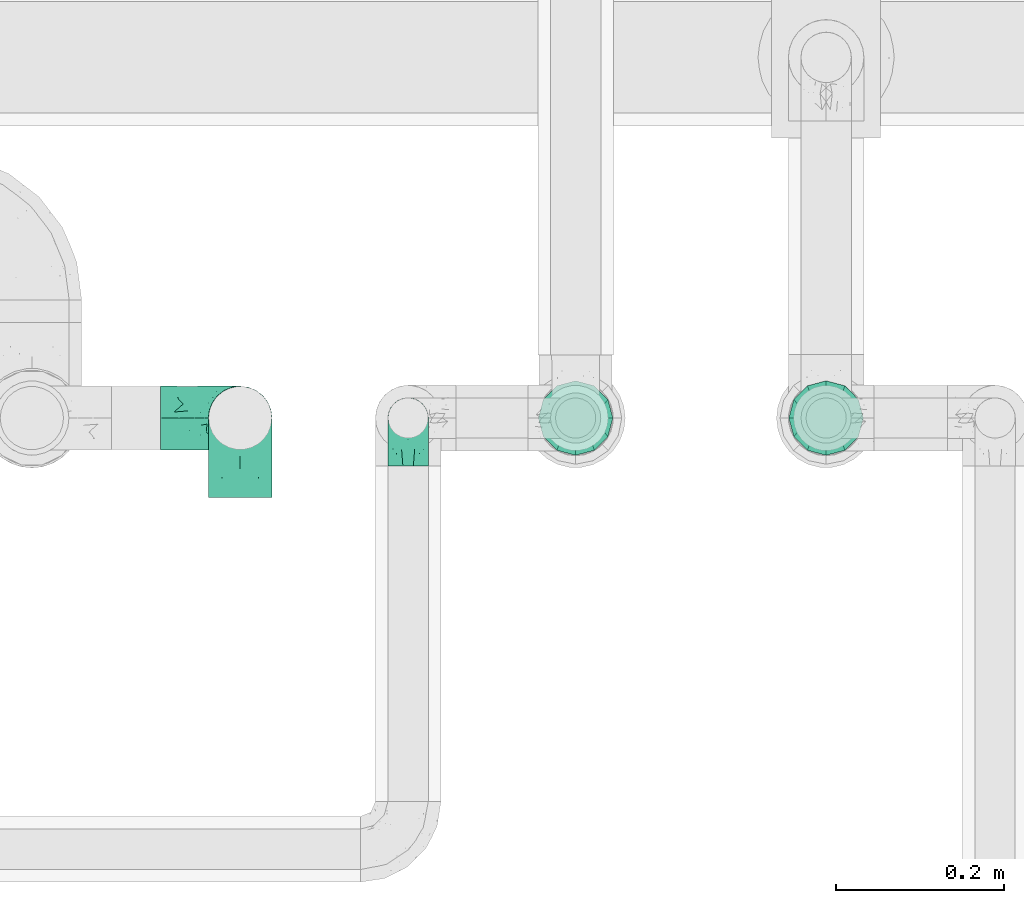
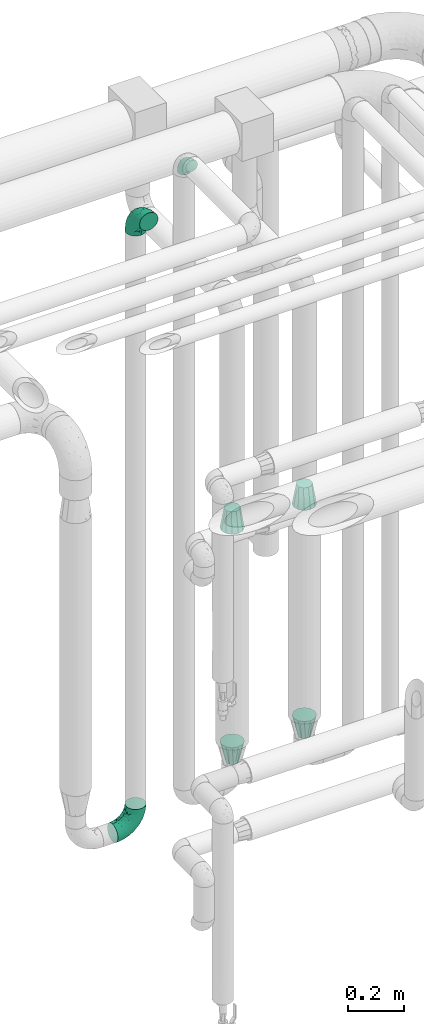
# One storey, part 717 of 827: 7 flow fittings.
"""IFC2X3 building model written with IfcOpenShell, lengths in millimetres."""

from ifc_helpers import new_model, entity, si_unit, converted_unit, derived_unit, direction, frame, origin, place, context, subcontext, project, spatial, faceted_brep, source, transform, mapped, material, type_object, type_shapes, element, save


model = new_model("IFC2X3")

# Units and contexts
model_context = context("Model", 3, precision=0.01, world=origin(), true_north=direction((6.12303176911189e-17, 1.0)))
body_context = subcontext(model_context, "Body", "Model", "MODEL_VIEW")
ifc_project = project(units=[si_unit("LENGTHUNIT", "METRE", prefix="MILLI"), si_unit("AREAUNIT", "SQUARE_METRE"), si_unit("VOLUMEUNIT", "CUBIC_METRE"), converted_unit("PLANEANGLEUNIT", "DEGREE", entity("IfcRatioMeasure", 0.0174532925199433), si_unit("PLANEANGLEUNIT", "RADIAN"), dimensions=[0, 0, 0, 0, 0, 0, 0]), si_unit("MASSUNIT", "GRAM", prefix="KILO"), derived_unit("MASSDENSITYUNIT", [(si_unit("MASSUNIT", "GRAM", prefix="KILO"), 1), (si_unit("LENGTHUNIT", "METRE"), -3)]), derived_unit("MOMENTOFINERTIAUNIT", [(si_unit("LENGTHUNIT", "METRE"), 4)]), si_unit("TIMEUNIT", "SECOND"), si_unit("FREQUENCYUNIT", "HERTZ"), si_unit("THERMODYNAMICTEMPERATUREUNIT", "DEGREE_CELSIUS"), derived_unit("THERMALTRANSMITTANCEUNIT", [(si_unit("MASSUNIT", "GRAM", prefix="KILO"), 1), (si_unit("THERMODYNAMICTEMPERATUREUNIT", "KELVIN"), -1), (si_unit("TIMEUNIT", "SECOND"), -3)]), derived_unit("VOLUMETRICFLOWRATEUNIT", [(si_unit("LENGTHUNIT", "METRE"), 3), (si_unit("TIMEUNIT", "SECOND"), -1)]), derived_unit("MASSFLOWRATEUNIT", [(si_unit("MASSUNIT", "GRAM", prefix="KILO"), 1), (si_unit("TIMEUNIT", "SECOND"), -1)]), derived_unit("ROTATIONALFREQUENCYUNIT", [(si_unit("TIMEUNIT", "SECOND"), -1)]), si_unit("ELECTRICCURRENTUNIT", "AMPERE"), si_unit("ELECTRICVOLTAGEUNIT", "VOLT"), si_unit("POWERUNIT", "WATT"), si_unit("FORCEUNIT", "NEWTON", prefix="KILO"), si_unit("ILLUMINANCEUNIT", "LUX"), si_unit("LUMINOUSFLUXUNIT", "LUMEN"), si_unit("LUMINOUSINTENSITYUNIT", "CANDELA"), derived_unit("USERDEFINED", [(si_unit("MASSUNIT", "GRAM", prefix="KILO"), -1), (si_unit("LENGTHUNIT", "METRE"), -2), (si_unit("TIMEUNIT", "SECOND"), 3), (si_unit("LUMINOUSFLUXUNIT", "LUMEN"), 1)]), derived_unit("LINEARVELOCITYUNIT", [(si_unit("LENGTHUNIT", "METRE"), 1), (si_unit("TIMEUNIT", "SECOND"), -1)]), si_unit("PRESSUREUNIT", "PASCAL"), derived_unit("USERDEFINED", [(si_unit("LENGTHUNIT", "METRE"), -2), (si_unit("MASSUNIT", "GRAM", prefix="KILO"), 1), (si_unit("TIMEUNIT", "SECOND"), -2)]), derived_unit("LINEARFORCEUNIT", [(si_unit("MASSUNIT", "GRAM", prefix="KILO"), 1), (si_unit("LENGTHUNIT", "METRE"), 1), (si_unit("TIMEUNIT", "SECOND"), -2), (si_unit("LENGTHUNIT", "METRE"), -1)]), derived_unit("PLANARFORCEUNIT", [(si_unit("MASSUNIT", "GRAM", prefix="KILO"), 1), (si_unit("LENGTHUNIT", "METRE"), 1), (si_unit("TIMEUNIT", "SECOND"), -2), (si_unit("LENGTHUNIT", "METRE"), -2)])], contexts=[model_context])

# Site, building, storey
site_placement = place(None, origin())
site = spatial("IfcSite", under=ifc_project, at=site_placement, CompositionType="ELEMENT")
building_placement = place(site_placement, origin())
building = spatial("IfcBuilding", under=site, at=building_placement, CompositionType="ELEMENT")
storey_placement = place(building_placement, frame((0.0, 0.0, 28200.0)))
storey = spatial("IfcBuildingStorey", under=building, at=storey_placement, Name="08", CompositionType="ELEMENT", Elevation=28200.0)

# Flow fittings
ifc_material = material()
pipe_fitting_type_1 = type_object("IfcPipeFittingType", Name="ADSK_1", PredefinedType="NOTDEFINED", material=ifc_material)
shared_shape_1 = source(origin(), body_context, "Body", "Brep", [
    faceted_brep([(-57.0, 12.07, -20.91), (-57.0, 6.25, -23.33), (-57.0, 0.0, -24.15), (-57.0, -6.25, -23.33), (-57.0, -12.08, -20.91), (-57.0, -17.08, -17.08), (-57.0, -20.91, -12.08), (-57.0, -23.33, -6.25), (-57.0, -24.15, 0.0), (-57.0, -23.33, 6.25), (-57.0, -20.91, 12.07), (-57.0, -17.08, 17.08), (-57.0, -12.08, 20.91), (-57.0, -6.25, 23.33), (-57.0, 0.0, 24.15), (-57.0, 6.25, 23.33), (-57.0, 12.07, 20.91), (-57.0, 17.08, 17.08), (-57.0, 20.91, 12.07), (-57.0, 23.33, 6.25), (-57.0, 24.15, 0.0), (-57.0, 23.33, -6.25), (-57.0, 20.91, -12.08), (-57.0, 17.08, -17.08), (0.0, 57.0, -24.15), (-6.25, 57.0, -23.33), (-12.07, 57.0, -20.91), (-17.08, 57.0, -17.08), (-20.91, 57.0, -12.08), (-23.33, 57.0, -6.25), (-24.15, 57.0, 0.0), (-23.33, 57.0, 6.25), (-20.91, 57.0, 12.07), (-17.08, 57.0, 17.08), (-12.07, 57.0, 20.91), (-6.25, 57.0, 23.33), (0.0, 57.0, 24.15), (6.25, 57.0, 23.33), (12.08, 57.0, 20.91), (17.08, 57.0, 17.08), (20.91, 57.0, 12.07), (23.33, 57.0, 6.25), (24.15, 57.0, 0.0), (23.33, 57.0, -6.25), (20.91, 57.0, -12.08), (17.08, 57.0, -17.08), (12.08, 57.0, -20.91), (6.25, 57.0, -23.33), (14.9, 21.14, 6.17), (13.61, 24.64, 12.48), (6.23, 8.95, 8.98), (-41.47, -21.06, 0.0), (-41.92, -18.38, 13.72), (-24.64, -13.61, 12.48), (-37.37, -13.24, 18.15), (-6.8, -4.93, 8.18), (-21.76, -15.19, 6.22), (-12.78, -9.18, 0.0), (-37.73, -20.51, 7.75), (-7.38, 7.38, 20.24), (-23.37, -4.26, 20.42), (-11.9, -3.19, 15.86), (-42.14, -8.7, 21.82), (13.24, 37.37, 18.15), (9.33, 23.53, 16.85), (4.26, 23.37, 20.42), (2.77, 10.92, 15.55), (-29.46, 0.91, 23.52), (-44.13, 20.56, 15.69), (-39.25, 26.33, 10.88), (-49.02, 22.92, 9.96), (-34.58, 23.87, 17.15), (-15.8, 6.8, 22.81), (-8.67, 20.47, 23.88), (-18.12, 12.9, 24.08), (-48.29, 14.92, 19.65), (-44.06, -2.85, 23.78), (-9.23, 48.95, 22.58), (-3.78, 42.74, 24.07), (-40.34, 4.26, 24.09), (-44.02, 26.14, 5.46), (-44.04, 9.88, 22.74), (-4.95, 16.87, 22.52), (-2.75, 1.43, 12.5), (-25.48, 40.98, 10.71), (20.51, 37.73, 7.75), (18.38, 41.92, 13.72), (8.7, 42.14, 21.82), (-25.95, -17.97, 0.0), (2.85, 44.06, 23.78), (21.06, 41.47, 0.0), (17.97, 25.95, 0.0), (-24.04, -9.27, 17.13), (-33.26, 33.26, 5.86), (-28.55, 40.57, 0.0), (-40.57, 28.55, 0.0), (-25.29, 47.19, 4.06), (-27.01, 31.1, 16.77), (-15.7, 43.95, 19.9), (-20.27, 45.22, 15.61), (-30.53, 31.98, 12.64), (-11.28, 38.33, 22.92), (-9.97, 27.88, 24.09), (-20.15, 30.26, 21.25), (-31.25, 11.75, 23.64), (-28.75, 7.23, 24.15), (-29.53, 18.06, 22.27), (-28.44, 24.21, 20.02), (-37.55, 17.7, 20.26), (-15.88, 29.25, 22.99), (-20.82, 20.82, 23.44), (-0.91, 29.46, 23.52), (-13.5, -7.67, 12.04), (1.49, 1.56, 5.16), (8.86, 10.35, 4.59), (0.38, -0.38, 0.0), (9.18, 12.78, 0.0), (-37.37, -13.24, -18.15), (8.86, 10.35, -4.59), (-45.22, 20.27, -15.61), (-43.95, 15.7, -19.9), (-38.33, 11.28, -22.92), (-48.95, 9.23, -22.58), (-47.19, 25.29, -4.06), (-33.26, 33.26, -5.86), (18.38, 41.92, -13.72), (-30.26, 20.15, -21.25), (2.85, 44.06, -23.78), (-4.26, 40.34, -24.09), (-40.98, 25.48, -10.71), (-41.92, -18.38, -13.72), (9.25, 23.5, -16.92), (4.26, 23.37, -20.42), (13.24, 37.37, -18.15), (-37.73, -20.51, -7.75), (-11.75, 31.25, -23.64), (-7.23, 28.75, -24.15), (-12.9, 18.12, -24.08), (8.7, 42.14, -21.82), (-44.06, -2.85, -23.78), (-6.8, 15.8, -22.81), (-20.47, 8.67, -23.88), (-24.64, -13.61, -12.48), (-42.74, 3.78, -24.07), (-18.06, 29.53, -22.27), (-24.21, 28.44, -20.02), (-27.88, 9.97, -24.09), (-31.1, 27.01, -16.77), (-26.14, 44.02, -5.46), (14.9, 21.14, -6.17), (20.51, 37.73, -7.75), (-9.88, 44.04, -22.74), (-20.56, 44.13, -15.69), (-21.76, -15.19, -6.22), (-13.5, -7.67, -12.04), (-24.14, -9.76, -16.74), (-11.9, -3.19, -15.86), (-14.92, 48.29, -19.65), (-23.37, -4.26, -20.42), (-0.91, 29.46, -23.52), (-26.33, 39.25, -10.88), (-23.87, 34.58, -17.15), (-42.14, -8.7, -21.82), (-22.92, 49.02, -9.96), (13.61, 24.64, -12.48), (-31.98, 30.53, -12.64), (-16.87, 4.95, -22.52), (-17.7, 37.55, -20.26), (-29.25, 15.88, -22.99), (-20.82, 20.82, -23.44), (-29.46, 0.91, -23.52), (-7.38, 7.38, -20.24), (2.77, 10.92, -15.55), (6.23, 8.95, -8.98), (-6.8, -4.93, -8.18), (-2.81, 1.41, -12.54), (1.49, 1.56, -5.16)], [[[0, 1, 2, 3, 4, 5, 6, 7, 8, 9, 10, 11, 12, 13, 14, 15, 16, 17, 18, 19, 20, 21, 22, 23]], [[24, 25, 26, 27, 28, 29, 30, 31, 32, 33, 34, 35, 36, 37, 38, 39, 40, 41, 42, 43, 44, 45, 46, 47]], [[48, 49, 50]], [[9, 8, 51]], [[52, 53, 54]], [[55, 56, 57]], [[10, 58, 52]], [[9, 58, 10]], [[59, 60, 61]], [[54, 12, 11]], [[54, 62, 12]], [[63, 39, 38]], [[64, 65, 66]], [[62, 60, 67]], [[68, 69, 70]], [[71, 69, 68]], [[72, 73, 74]], [[16, 75, 17]], [[13, 76, 14]], [[35, 77, 78]], [[14, 79, 15]], [[17, 68, 18]], [[14, 76, 79]], [[20, 19, 80]], [[70, 19, 18]], [[81, 15, 79]], [[15, 81, 16]], [[73, 72, 82]], [[66, 83, 50]], [[32, 31, 84]], [[85, 86, 49]], [[63, 87, 65]], [[56, 58, 88]], [[36, 89, 37]], [[85, 41, 40]], [[36, 35, 78]], [[90, 41, 85]], [[40, 39, 86]], [[12, 62, 13]], [[86, 85, 40]], [[48, 85, 49]], [[85, 91, 90]], [[87, 38, 37]], [[92, 60, 54]], [[80, 69, 93]], [[93, 94, 95]], [[10, 52, 11]], [[94, 96, 30]], [[97, 98, 99]], [[80, 93, 95]], [[100, 97, 84]], [[99, 98, 33]], [[101, 102, 78]], [[103, 101, 98]], [[96, 31, 30]], [[77, 98, 101]], [[77, 35, 34]], [[34, 33, 98]], [[9, 51, 58]], [[87, 63, 38]], [[104, 105, 74]], [[106, 103, 107]], [[106, 81, 104]], [[75, 68, 17]], [[108, 107, 71]], [[33, 32, 99]], [[109, 103, 110]], [[101, 109, 102]], [[89, 78, 111]], [[53, 52, 58]], [[54, 11, 52]], [[60, 62, 54]], [[88, 58, 51]], [[76, 62, 67]], [[53, 112, 92]], [[60, 59, 72]], [[39, 63, 86]], [[49, 86, 63]], [[89, 87, 37]], [[42, 41, 90]], [[111, 82, 65]], [[111, 65, 87]], [[65, 59, 66]], [[104, 81, 79]], [[75, 81, 108]], [[32, 84, 99]], [[97, 99, 84]], [[98, 97, 103]], [[106, 107, 108]], [[74, 102, 110]], [[111, 78, 102]], [[74, 110, 104]], [[74, 67, 72]], [[61, 92, 112]], [[66, 59, 61]], [[56, 53, 58]], [[66, 50, 49]], [[61, 112, 83]], [[66, 49, 64]], [[78, 89, 36]], [[87, 89, 111]], [[62, 76, 13]], [[79, 76, 67]], [[100, 93, 69]], [[96, 93, 84]], [[55, 113, 50]], [[113, 114, 50]], [[104, 79, 105]], [[106, 104, 110]], [[20, 80, 95]], [[85, 48, 91]], [[115, 114, 113]], [[116, 91, 48]], [[70, 80, 19]], [[93, 96, 94]], [[84, 31, 96]], [[103, 106, 110]], [[81, 106, 108]], [[103, 97, 107]], [[71, 107, 97]], [[71, 97, 100]], [[108, 71, 68]], [[79, 67, 105]], [[67, 74, 105]], [[115, 113, 57]], [[112, 56, 55]], [[56, 88, 57]], [[60, 72, 67]], [[82, 72, 59]], [[65, 82, 59]], [[82, 111, 73]], [[111, 102, 73]], [[102, 74, 73]], [[81, 75, 16]], [[68, 75, 108]], [[68, 70, 18]], [[80, 70, 69]], [[98, 77, 34]], [[78, 77, 101]], [[93, 100, 84]], [[71, 100, 69]], [[102, 109, 110]], [[101, 103, 109]], [[53, 92, 54]], [[61, 60, 92]], [[56, 112, 53]], [[83, 112, 55]], [[50, 83, 55]], [[61, 83, 66]], [[49, 63, 64]], [[65, 64, 63]], [[57, 113, 55]], [[114, 115, 116]], [[116, 48, 114]], [[48, 50, 114]], [[117, 5, 4]], [[116, 115, 118]], [[119, 120, 23]], [[121, 122, 120]], [[95, 123, 20]], [[0, 23, 120]], [[124, 95, 94]], [[125, 45, 44]], [[121, 120, 126]], [[24, 127, 128]], [[22, 21, 129]], [[0, 122, 1]], [[5, 117, 130]], [[131, 132, 133]], [[134, 88, 51]], [[135, 136, 137]], [[6, 5, 130]], [[46, 138, 47]], [[139, 3, 2]], [[140, 141, 137]], [[6, 134, 7]], [[134, 130, 142]], [[143, 2, 1]], [[144, 126, 145]], [[121, 146, 143]], [[147, 120, 119]], [[94, 148, 124]], [[149, 150, 91]], [[30, 29, 148]], [[151, 25, 128]], [[27, 152, 28]], [[134, 153, 88]], [[154, 155, 156]], [[27, 26, 157]], [[151, 26, 25]], [[155, 158, 156]], [[24, 47, 127]], [[1, 122, 143]], [[138, 132, 159]], [[160, 152, 161]], [[24, 128, 25]], [[46, 133, 138]], [[162, 117, 4]], [[148, 160, 124]], [[152, 160, 163]], [[154, 142, 155]], [[45, 125, 133]], [[133, 46, 45]], [[125, 164, 133]], [[51, 7, 134]], [[42, 90, 43]], [[165, 147, 129]], [[153, 134, 142]], [[43, 150, 44]], [[162, 4, 3]], [[141, 140, 166]], [[117, 162, 158]], [[163, 29, 28]], [[43, 90, 150]], [[123, 21, 20]], [[144, 151, 135]], [[157, 152, 27]], [[167, 145, 161]], [[23, 22, 119]], [[168, 126, 169]], [[121, 168, 146]], [[139, 143, 170]], [[142, 130, 117]], [[8, 7, 51]], [[134, 6, 130]], [[139, 162, 3]], [[170, 166, 158]], [[170, 158, 162]], [[158, 171, 156]], [[44, 150, 125]], [[91, 150, 90]], [[164, 125, 150]], [[132, 138, 133]], [[127, 138, 159]], [[131, 164, 172]], [[132, 171, 140]], [[135, 151, 128]], [[157, 151, 167]], [[22, 129, 119]], [[147, 119, 129]], [[120, 147, 126]], [[144, 145, 167]], [[137, 146, 169]], [[170, 143, 146]], [[137, 169, 135]], [[137, 159, 140]], [[171, 172, 156]], [[173, 174, 175]], [[156, 175, 154]], [[174, 57, 153]], [[132, 172, 171]], [[172, 164, 173]], [[143, 139, 2]], [[162, 139, 170]], [[138, 127, 47]], [[128, 127, 159]], [[165, 124, 160]], [[123, 124, 129]], [[149, 173, 164]], [[176, 174, 173]], [[135, 128, 136]], [[144, 135, 169]], [[150, 149, 164]], [[176, 118, 115]], [[149, 91, 116]], [[30, 148, 94]], [[163, 148, 29]], [[124, 123, 95]], [[129, 21, 123]], [[126, 144, 169]], [[151, 144, 167]], [[126, 147, 145]], [[161, 145, 147]], [[161, 147, 165]], [[167, 161, 152]], [[128, 159, 136]], [[159, 137, 136]], [[154, 153, 142]], [[132, 140, 159]], [[174, 176, 57]], [[57, 88, 153]], [[166, 140, 171]], [[158, 166, 171]], [[166, 170, 141]], [[170, 146, 141]], [[146, 137, 141]], [[151, 157, 26]], [[152, 157, 167]], [[152, 163, 28]], [[148, 163, 160]], [[120, 122, 0]], [[143, 122, 121]], [[124, 165, 129]], [[161, 165, 160]], [[146, 168, 169]], [[121, 126, 168]], [[142, 117, 155]], [[158, 155, 117]], [[175, 156, 172]], [[153, 154, 174]], [[173, 175, 172]], [[174, 154, 175]], [[164, 131, 133]], [[172, 132, 131]], [[176, 173, 118]], [[57, 176, 115]], [[173, 149, 118]], [[149, 116, 118]]]),
])
type_shapes(pipe_fitting_type_1, [shared_shape_1])
flow_fitting_placement = place(storey_placement, frame((59098.13, 17500.0, 3200.0), z_axis=(1.0, 0.0, 0.0), x_axis=(0.0, 0.0, 1.0)))
element("IfcFlowFitting", 1, at=flow_fitting_placement, inside=storey, type_object=pipe_fitting_type_1, material=ifc_material, Name="ADSK_1", ObjectType="ADSK_1", context=body_context, shape_type="MappedRepresentation", body=[
    mapped(shared_shape_1, transform((0.0, 0.0, 0.0), scale=1.0)),
])
pipe_fitting_type_2 = type_object("IfcPipeFittingType", Name="ADSK_1", PredefinedType="NOTDEFINED", material=ifc_material)
shared_shape_2 = source(origin(), body_context, "Body", "Brep", [
    faceted_brep([(-95.0, 19.02, -32.95), (-95.0, 9.85, -36.75), (-95.0, 0.0, -38.05), (-95.0, -9.85, -36.75), (-95.0, -19.03, -32.95), (-95.0, -26.91, -26.91), (-95.0, -32.95, -19.03), (-95.0, -36.75, -9.85), (-95.0, -38.05, 0.0), (-95.0, -36.75, 9.85), (-95.0, -32.95, 19.02), (-95.0, -26.91, 26.91), (-95.0, -19.03, 32.95), (-95.0, -9.85, 36.75), (-95.0, 0.0, 38.05), (-95.0, 9.85, 36.75), (-95.0, 19.02, 32.95), (-95.0, 26.91, 26.91), (-95.0, 32.95, 19.02), (-95.0, 36.75, 9.85), (-95.0, 38.05, 0.0), (-95.0, 36.75, -9.85), (-95.0, 32.95, -19.03), (-95.0, 26.91, -26.91), (0.0, 95.0, -38.05), (-9.85, 95.0, -36.75), (-19.02, 95.0, -32.95), (-26.91, 95.0, -26.91), (-32.95, 95.0, -19.03), (-36.75, 95.0, -9.85), (-38.05, 95.0, 0.0), (-36.75, 95.0, 9.85), (-32.95, 95.0, 19.02), (-26.91, 95.0, 26.91), (-19.02, 95.0, 32.95), (-9.85, 95.0, 36.75), (0.0, 95.0, 38.05), (9.85, 95.0, 36.75), (19.03, 95.0, 32.95), (26.91, 95.0, 26.91), (32.95, 95.0, 19.02), (36.75, 95.0, 9.85), (38.05, 95.0, 0.0), (36.75, 95.0, -9.85), (32.95, 95.0, -19.03), (26.91, 95.0, -26.91), (19.03, 95.0, -32.95), (9.85, 95.0, -36.75), (-7.99, -4.96, 6.3), (-0.92, 0.92, 0.0), (4.62, 8.1, 8.01), (-76.19, -35.57, 0.0), (-64.32, -32.32, 12.43), (20.51, 62.45, 28.68), (-60.56, -33.52, 0.0), (-70.4, -13.47, 34.42), (-39.61, -5.88, 32.32), (-49.6, 2.07, 37.1), (-70.34, -28.81, 21.71), (14.64, 40.81, 26.5), (5.88, 39.61, 32.32), (3.59, 20.77, 25.31), (-40.45, 68.06, 16.75), (-62.45, -20.51, 28.68), (-44.52, -26.87, 0.0), (-28.47, -20.22, 0.0), (-26.43, -17.83, 8.75), (-76.1, 39.63, 10.76), (-72.74, 37.58, 18.19), (-60.35, 46.18, 14.61), (-13.4, 13.4, 32.12), (-20.77, -3.59, 25.31), (-14.66, 81.47, 35.56), (-6.22, 71.26, 37.92), (-57.5, 42.48, 22.79), (-15.0, 34.74, 37.7), (-27.1, 12.08, 36.05), (-9.2, 28.81, 35.63), (-79.98, 23.7, 30.95), (-73.68, -4.3, 37.48), (-30.74, 21.67, 37.97), (-62.36, 47.59, 6.79), (-72.71, 32.83, 24.69), (-67.42, 7.02, 37.95), (-32.13, 75.27, 24.51), (-43.46, 51.47, 26.26), (-24.98, 73.15, 31.29), (20.59, 41.28, 19.85), (7.79, 16.09, 15.86), (-73.21, 42.39, 0.0), (-54.73, 54.73, 0.0), (-73.44, 15.79, 35.79), (-5.94, 4.32, 20.43), (28.81, 70.34, 21.71), (32.32, 64.32, 12.43), (-53.59, 26.2, 35.09), (-52.02, 19.31, 37.21), (21.38, 33.53, 10.34), (26.87, 44.52, 0.0), (-48.28, 12.14, 38.05), (4.3, 73.68, 37.48), (-44.08, -25.52, 12.79), (-41.28, -20.59, 19.85), (35.57, 76.19, 0.0), (-47.26, 54.3, 20.18), (-47.4, 61.99, 8.58), (-42.39, 73.21, 0.0), (-39.67, 78.86, 7.21), (-45.69, 36.84, 33.11), (-32.83, 50.13, 33.35), (13.47, 70.4, 34.42), (-18.25, 63.73, 36.07), (-40.63, -13.75, 27.22), (-16.63, 46.37, 37.95), (-53.47, 38.79, 28.59), (-26.07, 48.54, 36.15), (-34.51, 34.51, 36.86), (-2.07, 49.6, 37.1), (-22.79, -10.49, 19.23), (-61.73, 28.67, 31.87), (9.65, 14.7, 0.0), (20.22, 28.47, 0.0), (33.52, 60.56, 0.0), (-11.42, -5.44, 13.25), (-14.7, -9.65, 0.0), (-81.47, 14.66, -35.56), (-62.45, -20.51, -28.68), (-71.26, 6.22, -37.92), (-75.27, 32.13, -24.51), (-73.15, 24.98, -31.29), (13.47, 70.4, -34.42), (5.88, 39.61, -32.32), (-2.07, 49.6, -37.1), (-78.86, 39.67, -7.21), (-70.4, -13.47, -34.42), (-39.61, -5.88, -32.32), (-61.99, 47.4, -8.58), (32.32, 64.32, -12.43), (28.81, 70.34, -21.71), (-63.73, 18.25, -36.07), (-50.13, 32.83, -33.35), (4.3, 73.68, -37.48), (-7.02, 67.42, -37.95), (-39.63, 76.1, -10.76), (-46.18, 60.35, -14.61), (-47.59, 62.36, -6.79), (-64.32, -32.32, -12.43), (-26.2, 53.59, -35.09), (-15.79, 73.44, -35.79), (-19.31, 52.02, -37.21), (-37.58, 72.74, -18.19), (-70.34, -28.81, -21.71), (-42.48, 57.5, -22.79), (-38.79, 53.47, -28.59), (-51.47, 43.46, -26.26), (-32.83, 72.71, -24.69), (-46.37, 16.63, -37.95), (-73.68, -4.3, -37.48), (-41.28, -20.59, -19.85), (-44.08, -25.52, -12.79), (13.75, 40.63, -27.22), (20.51, 62.45, -28.68), (-68.06, 40.45, -16.75), (-54.3, 47.26, -20.18), (-12.14, 48.28, -38.05), (-21.67, 30.74, -37.97), (-36.84, 45.69, -33.11), (-11.42, -5.44, -13.25), (7.79, 16.09, -15.86), (4.62, 8.1, -8.01), (-23.7, 79.98, -30.95), (-26.43, -17.83, -8.75), (-7.99, -4.96, -6.3), (-40.81, -14.64, -26.5), (-20.77, -3.59, -25.31), (-34.74, 15.0, -37.7), (-12.08, 27.1, -36.05), (-28.81, 9.2, -35.63), (-22.79, -10.49, -19.23), (21.38, 33.53, -10.34), (20.59, 41.28, -19.85), (-48.54, 26.07, -36.15), (-49.6, 2.07, -37.1), (-13.4, 13.4, -32.12), (3.59, 20.77, -25.31), (-28.67, 61.73, -31.87), (-34.51, 34.51, -36.86), (-5.94, 4.32, -20.43)], [[[0, 1, 2, 3, 4, 5, 6, 7, 8, 9, 10, 11, 12, 13, 14, 15, 16, 17, 18, 19, 20, 21, 22, 23]], [[24, 25, 26, 27, 28, 29, 30, 31, 32, 33, 34, 35, 36, 37, 38, 39, 40, 41, 42, 43, 44, 45, 46, 47]], [[48, 49, 50]], [[51, 52, 9]], [[53, 39, 38]], [[9, 52, 10]], [[54, 52, 51]], [[55, 56, 57]], [[11, 10, 58]], [[59, 60, 61]], [[32, 31, 62]], [[63, 12, 11]], [[63, 55, 12]], [[64, 65, 66]], [[67, 68, 69]], [[70, 56, 71]], [[35, 72, 73]], [[69, 68, 74]], [[75, 76, 77]], [[16, 78, 17]], [[13, 79, 14]], [[76, 75, 80]], [[67, 69, 81]], [[18, 17, 82]], [[14, 79, 83]], [[20, 19, 67]], [[84, 85, 86]], [[87, 61, 88]], [[89, 81, 90]], [[18, 82, 68]], [[15, 91, 16]], [[14, 83, 15]], [[71, 92, 61]], [[17, 78, 82]], [[93, 87, 94]], [[95, 91, 96]], [[97, 98, 94]], [[86, 72, 34]], [[96, 99, 80]], [[37, 36, 100]], [[40, 39, 93]], [[40, 94, 41]], [[64, 66, 101]], [[93, 94, 40]], [[58, 102, 63]], [[94, 103, 41]], [[94, 87, 97]], [[104, 69, 74]], [[34, 33, 86]], [[105, 69, 104]], [[52, 58, 10]], [[106, 107, 30]], [[108, 109, 85]], [[105, 106, 90]], [[53, 110, 60]], [[86, 111, 72]], [[86, 109, 111]], [[33, 84, 86]], [[12, 55, 13]], [[112, 56, 63]], [[110, 38, 37]], [[34, 72, 35]], [[36, 35, 73]], [[111, 113, 73]], [[105, 107, 106]], [[110, 53, 38]], [[74, 114, 85]], [[91, 15, 83]], [[105, 90, 81]], [[107, 62, 31]], [[33, 32, 84]], [[115, 109, 116]], [[111, 115, 113]], [[100, 73, 117]], [[56, 55, 63]], [[79, 55, 57]], [[102, 118, 112]], [[56, 70, 76]], [[100, 110, 37]], [[117, 77, 60]], [[117, 60, 110]], [[60, 70, 61]], [[58, 52, 101]], [[63, 11, 58]], [[39, 53, 93]], [[87, 93, 53]], [[96, 91, 83]], [[78, 91, 119]], [[32, 62, 84]], [[84, 62, 104]], [[86, 85, 109]], [[85, 114, 108]], [[80, 113, 116]], [[117, 73, 113]], [[80, 116, 96]], [[80, 57, 76]], [[71, 112, 118]], [[61, 87, 59]], [[62, 107, 105]], [[97, 120, 121]], [[70, 71, 61]], [[71, 118, 92]], [[73, 100, 36]], [[110, 100, 117]], [[55, 79, 13]], [[83, 79, 57]], [[96, 83, 99]], [[116, 108, 95]], [[50, 97, 88]], [[97, 87, 88]], [[50, 49, 120]], [[122, 94, 98]], [[89, 20, 67]], [[105, 81, 69]], [[89, 67, 81]], [[68, 19, 18]], [[68, 67, 19]], [[74, 68, 82]], [[114, 82, 119]], [[74, 85, 104]], [[82, 114, 74]], [[114, 119, 108]], [[95, 108, 119]], [[116, 109, 108]], [[123, 48, 50]], [[97, 50, 120]], [[123, 50, 88]], [[91, 95, 119]], [[116, 95, 96]], [[84, 104, 85]], [[104, 62, 105]], [[83, 57, 99]], [[57, 80, 99]], [[66, 48, 123]], [[66, 124, 48]], [[118, 66, 123]], [[124, 66, 65]], [[66, 118, 101]], [[54, 64, 52]], [[124, 49, 48]], [[30, 107, 31]], [[91, 78, 16]], [[82, 78, 119]], [[56, 76, 57]], [[77, 76, 70]], [[60, 77, 70]], [[77, 117, 75]], [[117, 113, 75]], [[113, 80, 75]], [[9, 8, 51]], [[103, 94, 122]], [[103, 42, 41]], [[73, 72, 111]], [[113, 115, 116]], [[111, 109, 115]], [[102, 112, 63]], [[71, 56, 112]], [[118, 102, 101]], [[92, 123, 88]], [[123, 92, 118]], [[61, 92, 88]], [[87, 53, 59]], [[60, 59, 53]], [[97, 121, 98]], [[58, 101, 102]], [[64, 101, 52]], [[125, 1, 0]], [[126, 5, 4]], [[2, 1, 127]], [[1, 125, 127]], [[128, 129, 23]], [[130, 131, 132]], [[89, 133, 20]], [[126, 134, 135]], [[136, 89, 90]], [[137, 138, 44]], [[139, 129, 140]], [[24, 141, 142]], [[143, 144, 145]], [[125, 129, 139]], [[6, 146, 7]], [[147, 148, 149]], [[146, 51, 7]], [[143, 150, 144]], [[146, 6, 151]], [[152, 153, 154]], [[126, 4, 134]], [[0, 23, 129]], [[28, 155, 150]], [[43, 42, 103]], [[54, 146, 64]], [[139, 156, 127]], [[157, 3, 2]], [[151, 158, 159]], [[160, 131, 161]], [[22, 21, 162]], [[136, 144, 163]], [[149, 164, 165]], [[24, 142, 25]], [[166, 140, 154]], [[154, 129, 128]], [[143, 30, 29]], [[167, 168, 169]], [[155, 28, 27]], [[26, 170, 27]], [[171, 167, 172]], [[26, 25, 148]], [[27, 170, 155]], [[173, 135, 174]], [[144, 150, 152]], [[175, 176, 177]], [[24, 47, 141]], [[45, 161, 46]], [[148, 25, 142]], [[176, 175, 165]], [[64, 159, 171]], [[138, 45, 44]], [[130, 46, 161]], [[137, 44, 43]], [[178, 159, 158]], [[137, 103, 122]], [[163, 144, 152]], [[136, 133, 89]], [[103, 137, 43]], [[6, 5, 151]], [[178, 158, 173]], [[134, 4, 3]], [[178, 173, 174]], [[137, 98, 179]], [[145, 90, 106]], [[138, 180, 161]], [[46, 130, 47]], [[136, 90, 145]], [[133, 162, 21]], [[23, 22, 128]], [[139, 140, 181]], [[139, 181, 156]], [[157, 127, 182]], [[157, 134, 3]], [[182, 177, 135]], [[182, 135, 134]], [[135, 183, 174]], [[131, 130, 161]], [[141, 130, 132]], [[160, 180, 184]], [[131, 183, 176]], [[5, 126, 151]], [[158, 151, 126]], [[180, 138, 137]], [[161, 45, 138]], [[149, 148, 142]], [[170, 148, 185]], [[22, 162, 128]], [[128, 162, 163]], [[129, 154, 140]], [[154, 153, 166]], [[165, 156, 186]], [[182, 127, 156]], [[165, 186, 149]], [[165, 132, 176]], [[131, 184, 183]], [[187, 167, 178]], [[184, 168, 187]], [[167, 169, 172]], [[184, 180, 168]], [[174, 183, 184]], [[127, 157, 2]], [[134, 157, 182]], [[130, 141, 47]], [[142, 141, 132]], [[149, 142, 164]], [[186, 166, 147]], [[180, 179, 168]], [[169, 179, 120]], [[137, 179, 180]], [[179, 121, 120]], [[106, 30, 143]], [[136, 145, 144]], [[106, 143, 145]], [[150, 29, 28]], [[150, 143, 29]], [[152, 150, 155]], [[153, 155, 185]], [[152, 154, 163]], [[155, 153, 152]], [[153, 185, 166]], [[147, 166, 185]], [[186, 140, 166]], [[169, 120, 49]], [[169, 49, 172]], [[179, 169, 168]], [[148, 147, 185]], [[186, 147, 149]], [[128, 163, 154]], [[163, 162, 136]], [[142, 132, 164]], [[132, 165, 164]], [[171, 124, 65]], [[124, 171, 172]], [[64, 146, 159]], [[171, 159, 178]], [[171, 65, 64]], [[172, 49, 124]], [[162, 133, 136]], [[20, 133, 21]], [[148, 170, 26]], [[155, 170, 185]], [[131, 176, 132]], [[177, 176, 183]], [[135, 177, 183]], [[177, 182, 175]], [[182, 156, 175]], [[156, 165, 175]], [[51, 146, 54]], [[51, 8, 7]], [[129, 125, 0]], [[127, 125, 139]], [[140, 186, 181]], [[156, 181, 186]], [[158, 126, 173]], [[135, 173, 126]], [[187, 178, 174]], [[171, 178, 167]], [[184, 187, 174]], [[167, 187, 168]], [[180, 160, 161]], [[184, 131, 160]], [[98, 137, 122]], [[98, 121, 179]], [[151, 159, 146]]]),
])
type_shapes(pipe_fitting_type_2, [shared_shape_2])
for number, where, z_axis, x_axis, name in (
    (2, (58897.91, 17500.0, 3050.0), (1.0, 0.0, 0.0), (0.0, 0.0, 1.0), "ADSK_1"),
    (3, (58897.91, 17500.0, 350.0), (0.0, 1.0, 0.0), (0.0, 0.0, -1.0), "ADSK_1"),
):
    element("IfcFlowFitting", number, at=place(storey_placement, frame(where, z_axis=z_axis, x_axis=x_axis)), inside=storey, type_object=pipe_fitting_type_2, material=ifc_material, Name=name, ObjectType="ADSK_1", context=body_context, shape_type="MappedRepresentation", body=[
        mapped(shared_shape_2, transform((0.0, 0.0, 0.0), scale=1.0)),
    ])
pipe_fitting_type_3 = type_object("IfcPipeFittingType", Name="ADSK_1", PredefinedType="NOTDEFINED", material=ifc_material)
shared_shape_3 = source(origin(), body_context, "Body", "Brep", [
    faceted_brep([(89.0, -19.54, 14.2), (89.0, -21.84, 7.1), (89.0, -24.15, 0.0), (89.0, -21.84, -7.1), (89.0, -19.54, -14.2), (89.0, -13.5, -18.58), (89.0, -7.46, -22.97), (89.0, 0.0, -22.97), (89.0, 7.46, -22.97), (89.0, 13.5, -18.58), (89.0, 19.54, -14.2), (89.0, 21.84, -7.1), (89.0, 24.15, 0.0), (89.0, 21.84, 7.1), (89.0, 19.54, 14.2), (89.0, 13.5, 18.58), (89.0, 7.46, 22.97), (89.0, 0.0, 22.97), (89.0, -7.46, 22.97), (89.0, -13.5, 18.58), (0.0, -38.49, 22.22), (0.0, -30.36, 30.36), (0.0, -22.22, 38.49), (0.0, -11.11, 41.47), (0.0, 0.0, 44.45), (0.0, 11.11, 41.47), (0.0, 22.22, 38.49), (0.0, 30.36, 30.36), (0.0, 38.49, 22.22), (0.0, 42.23, 8.3), (0.0, 44.45, 0.0), (0.0, 42.23, -8.3), (0.0, 38.49, -22.23), (0.0, 30.36, -30.36), (0.0, 22.23, -38.49), (0.0, 11.11, -41.47), (0.0, 0.0, -44.45), (0.0, -11.11, -41.47), (0.0, -22.23, -38.49), (0.0, -30.36, -30.36), (0.0, -38.49, -22.23), (0.0, -42.23, -8.3), (0.0, -44.45, 0.0), (0.0, -42.23, 8.3)], [[[0, 1, 2, 3, 4, 5, 6, 7, 8, 9, 10, 11, 12, 13, 14, 15, 16, 17, 18, 19]], [[20, 21, 22, 23, 24, 25, 26, 27, 28, 29, 30, 31, 32, 33, 34, 35, 36, 37, 38, 39, 40, 41, 42, 43]], [[33, 9, 34]], [[32, 10, 33]], [[9, 33, 10]], [[32, 11, 10]], [[31, 12, 11]], [[38, 6, 5]], [[9, 8, 34]], [[35, 34, 8]], [[6, 37, 7]], [[8, 7, 35]], [[4, 39, 5]], [[2, 42, 41]], [[37, 36, 7]], [[2, 41, 3]], [[32, 31, 11]], [[6, 38, 37]], [[12, 31, 30]], [[3, 40, 4]], [[4, 40, 39]], [[40, 3, 41]], [[38, 5, 39]], [[35, 7, 36]], [[21, 19, 22]], [[20, 0, 21]], [[19, 21, 0]], [[20, 1, 0]], [[43, 2, 1]], [[26, 16, 15]], [[19, 18, 22]], [[23, 22, 18]], [[16, 25, 17]], [[18, 17, 23]], [[14, 27, 15]], [[12, 30, 29]], [[25, 24, 17]], [[12, 29, 13]], [[20, 43, 1]], [[16, 26, 25]], [[2, 43, 42]], [[13, 28, 14]], [[14, 28, 27]], [[28, 13, 29]], [[26, 15, 27]], [[23, 17, 24]]]),
])
type_shapes(pipe_fitting_type_3, [shared_shape_3])
for number, where, z_axis, x_axis, name in (
    (4, (59596.67, 17500.0, 589.0), (0.0, 1.0, 0.0), (0.0, 0.0, -1.0), "ADSK_1"),
    (5, (59297.89, 17500.0, 579.0), (0.0, 1.0, 0.0), (0.0, 0.0, -1.0), "ADSK_1"),
):
    element("IfcFlowFitting", number, at=place(storey_placement, frame(where, z_axis=z_axis, x_axis=x_axis)), inside=storey, type_object=pipe_fitting_type_3, material=ifc_material, Name=name, ObjectType="ADSK_1", context=body_context, shape_type="MappedRepresentation", body=[
        mapped(shared_shape_3, transform((0.0, 0.0, 0.0), scale=1.0)),
    ])
pipe_fitting_type_4 = type_object("IfcPipeFittingType", Name="ADSK_1", PredefinedType="NOTDEFINED", material=ifc_material)
shared_shape_4 = source(origin(), body_context, "Body", "Brep", [
    faceted_brep([(89.0, -44.45, 0.0), (89.0, -42.1, -8.76), (89.0, -38.49, -22.22), (89.0, -30.36, -30.36), (89.0, -22.23, -38.49), (89.0, -11.11, -41.47), (89.0, 0.0, -44.45), (89.0, 11.11, -41.47), (89.0, 22.22, -38.49), (89.0, 30.36, -30.36), (89.0, 38.49, -22.22), (89.0, 42.1, -8.76), (89.0, 44.45, 0.0), (89.0, 42.1, 8.76), (89.0, 38.49, 22.23), (89.0, 30.36, 30.36), (89.0, 22.22, 38.49), (89.0, 11.11, 41.47), (89.0, 0.0, 44.45), (89.0, -11.11, 41.47), (89.0, -22.23, 38.49), (89.0, -30.36, 30.36), (89.0, -38.49, 22.23), (89.0, -42.1, 8.76), (0.0, 30.15, 0.0), (0.0, 27.27, -8.86), (0.0, 24.39, -17.72), (0.0, 16.85, -23.2), (0.0, 9.32, -28.67), (0.0, 0.0, -28.67), (0.0, -9.32, -28.67), (0.0, -16.85, -23.2), (0.0, -24.39, -17.72), (0.0, -27.27, -8.86), (0.0, -30.15, 0.0), (0.0, -27.27, 8.86), (0.0, -24.39, 17.72), (0.0, -16.85, 23.2), (0.0, -9.32, 28.67), (0.0, 0.0, 28.67), (0.0, 9.32, 28.67), (0.0, 16.85, 23.2), (0.0, 24.39, 17.72), (0.0, 27.27, 8.86)], [[[0, 1, 2, 3, 4, 5, 6, 7, 8, 9, 10, 11, 12, 13, 14, 15, 16, 17, 18, 19, 20, 21, 22, 23]], [[24, 25, 26, 27, 28, 29, 30, 31, 32, 33, 34, 35, 36, 37, 38, 39, 40, 41, 42, 43]], [[2, 33, 32]], [[28, 7, 29]], [[29, 5, 30]], [[24, 12, 11]], [[3, 32, 31]], [[34, 1, 0]], [[1, 34, 33]], [[8, 28, 27]], [[2, 1, 33]], [[31, 4, 3]], [[2, 32, 3]], [[11, 25, 24]], [[26, 10, 9]], [[10, 25, 11]], [[28, 8, 7]], [[27, 26, 9]], [[26, 25, 10]], [[31, 30, 4]], [[8, 27, 9]], [[29, 7, 6]], [[5, 29, 6]], [[5, 4, 30]], [[14, 43, 42]], [[38, 19, 39]], [[39, 17, 40]], [[34, 0, 23]], [[15, 42, 41]], [[24, 13, 12]], [[13, 24, 43]], [[20, 38, 37]], [[14, 13, 43]], [[41, 16, 15]], [[14, 42, 15]], [[23, 35, 34]], [[36, 22, 21]], [[22, 35, 23]], [[38, 20, 19]], [[37, 36, 21]], [[36, 35, 22]], [[41, 40, 16]], [[20, 37, 21]], [[39, 19, 18]], [[17, 39, 18]], [[17, 16, 40]]]),
])
type_shapes(pipe_fitting_type_4, [shared_shape_4])
for number, where, z_axis, x_axis, name in (
    (6, (59596.67, 17500.0, 1602.24), (1.0, 0.0, 0.0), (0.0, 0.0, -1.0), "ADSK_1"),
    (7, (59297.89, 17500.0, 1602.24), (1.0, 0.0, 0.0), (0.0, 0.0, -1.0), "ADSK_1"),
):
    element("IfcFlowFitting", number, at=place(storey_placement, frame(where, z_axis=z_axis, x_axis=x_axis)), inside=storey, type_object=pipe_fitting_type_4, material=ifc_material, Name=name, ObjectType="ADSK_1", context=body_context, shape_type="MappedRepresentation", body=[
        mapped(shared_shape_4, transform((0.0, 0.0, 0.0), scale=1.0)),
    ])

save(model, "model.ifc")
